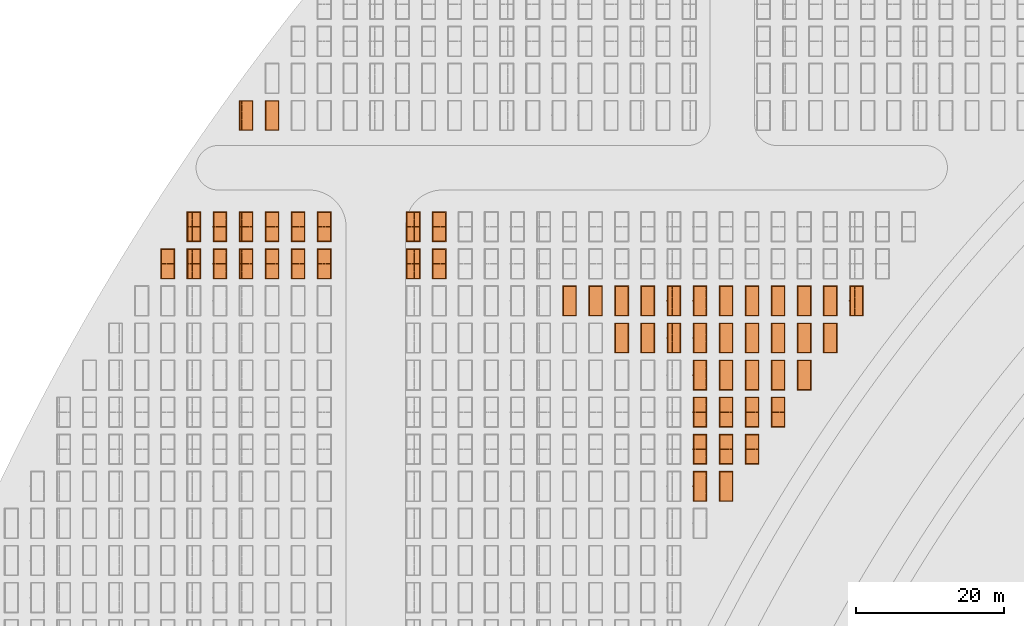
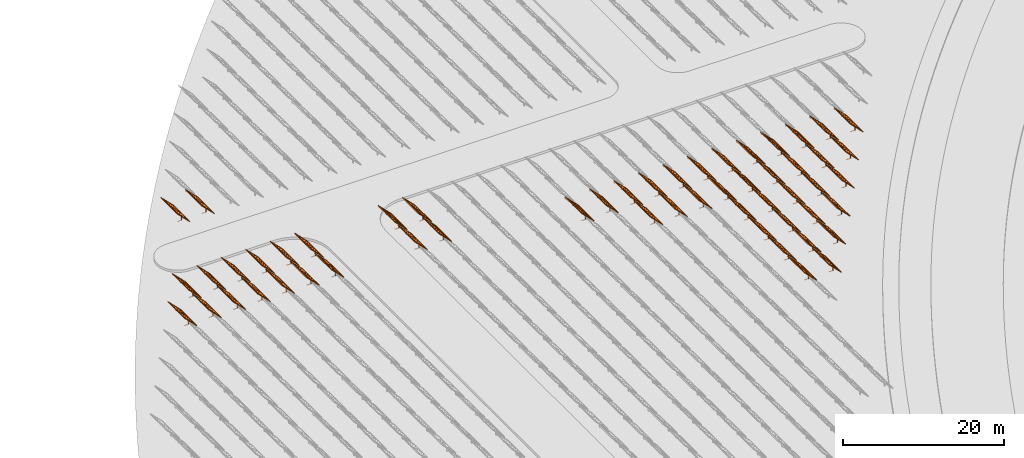
# One storey, part 32 of 39: 54 proxies.
"""IFC2X3 building model written with IfcOpenShell, lengths in millimetres."""

from ifc_helpers import new_model, entity, si_unit, converted_unit, derived_unit, direction, frame, frame_2d, origin, origin_2d_with_axis, place, context, subcontext, project, spatial, polyline, rectangle, outline, extrude, source, transform, mapped, material, material_list, element, save


model = new_model("IFC2X3")

# Units and contexts
model_context = context("Model", 3, precision=1e-06, world=origin(), true_north=direction((2.0, 6.12303176911189e-17, 1.0)))
context_of_model = context(None, 3, precision=1e-06, world=origin(), true_north=direction((2.0, 6.12303176911189e-17, 1.0)))
body_context = subcontext(model_context, "Body", "Model", "MODEL_VIEW")
ifc_project = project(units=[si_unit("LENGTHUNIT", "METRE", prefix="MILLI"), si_unit("AREAUNIT", "SQUARE_METRE", prefix="MILLI"), si_unit("VOLUMEUNIT", "CUBIC_METRE", prefix="MILLI"), converted_unit("PLANEANGLEUNIT", "DEGREE", entity("IfcRatioMeasure", 0.0174532925199433), si_unit("PLANEANGLEUNIT", "RADIAN"), dimensions=[0, 0, 0, 0, 0, 0, 0]), si_unit("MASSUNIT", "GRAM", prefix="KILO"), si_unit("TIMEUNIT", "SECOND"), si_unit("THERMODYNAMICTEMPERATUREUNIT", "KELVIN"), derived_unit("THERMALTRANSMITTANCEUNIT", [(si_unit("MASSUNIT", "GRAM", prefix="KILO"), 1), (si_unit("THERMODYNAMICTEMPERATUREUNIT", "KELVIN"), -1), (si_unit("TIMEUNIT", "SECOND"), -3)]), derived_unit("VOLUMETRICFLOWRATEUNIT", [(si_unit("LENGTHUNIT", "METRE"), 3), (si_unit("TIMEUNIT", "SECOND"), -1)])], contexts=[model_context, context_of_model])

# Site, building, storey
site_placement = place(None, origin())
site = spatial("IfcSite", under=ifc_project, at=site_placement, CompositionType="ELEMENT")
building_placement = place(site_placement, origin())
building = spatial("IfcBuilding", under=site, at=building_placement, CompositionType="ELEMENT")
storey_placement = place(building_placement, frame((0.0, 0.0, 4000.0)))
storey = spatial("IfcBuildingStorey", under=building, at=storey_placement, Name="Level 2", CompositionType="ELEMENT", Elevation=4000.0)

# Proxies
ifc_material_1 = material(Name="Stand-Steel")
ifc_material_2 = material(Name="Aluminium")
ifc_material_3 = material(Name="Glass")
ifc_material_list_1 = material_list([ifc_material_1, ifc_material_2, ifc_material_3])
shared_shape = source(origin(), body_context, "Body", "SweptSolid", [
    extrude(outline(polyline([(-629.526235435404, -220.0), (329.763117717702, -220.0), (329.763117717703, 410.0), (299.763117717703, 410.0), (299.763117717702, -190.0), (-629.526235435404, -190.0), (-629.526235435404, -220.0)])), frame((-190.00003127179, -100.0, 299.763117717707), z_axis=(0.0, 1.0, 0.0), x_axis=(0.0, 0.0, -1.0)), (0.0, 0.0, 1.0), 200.0),
    extrude(rectangle(XDim=20.0000000000001, YDim=200.0, at=frame_2d((0.0, -7.105427357601e-14), x_axis=(0.0, 1.0))), frame((-7.07109908365613, 0.0, 922.21828534124), z_axis=(-0.70710678118654, 0.0, 0.707106781186555), x_axis=(0.0, 1.0, 0.0)), (0.0, 0.0, 1.0), 2600.0),
    extrude(rectangle(XDim=24.9999999999997, YDim=24.9999999999999, at=frame_2d((2.87769807982841e-13, -9.50350909079134e-14), x_axis=(1.0, 0.0))), frame((-1449.56292018118, -1950.0, 2449.57494522722), z_axis=(0.0, 1.0, 0.0), x_axis=(-0.707106781186548, 0.0, -0.707106781186548)), (0.0, 0.0, 1.0), 3900.0),
    extrude(rectangle(XDim=24.9999999999999, YDim=25.0000000000001, at=origin_2d_with_axis()), frame((-1096.0095295879, -1950.0, 2096.02155463395), z_axis=(0.0, 1.0, 0.0), x_axis=(-0.707106781186542, 0.0, -0.707106781186553)), (0.0, 0.0, 1.0), 3900.0),
    extrude(rectangle(XDim=24.9999999999999, YDim=25.0000000000001, at=origin_2d_with_axis()), frame((-742.456138994631, -1950.0, 1742.46816404067), z_axis=(0.0, 1.0, 0.0), x_axis=(-0.707106781186542, 0.0, -0.707106781186553)), (0.0, 0.0, 1.0), 3900.0),
    extrude(rectangle(XDim=25.0, YDim=24.9999999999997, at=frame_2d((-7.19424519957101e-14, 1.19904086659517e-13), x_axis=(1.0, 0.0))), frame((-388.902748401358, -1950.0, 1388.9147734474), z_axis=(0.0, 1.0, 0.0), x_axis=(-0.707106781186545, 0.0, -0.70710678118655)), (0.0, 0.0, 1.0), 3900.0),
    extrude(rectangle(XDim=25.0000000000002, YDim=25.0, at=frame_2d((1.35891298214119e-13, 6.21724893790088e-15), x_axis=(0.0, 1.0))), frame((-35.3553703311048, 1500.0, 1035.35537033109), z_axis=(-0.707106781186544, 0.0, 0.707106781186551), x_axis=(0.0, 1.0, 0.0)), (0.0, 0.0, 1.0), 2440.0),
    extrude(rectangle(XDim=25.0000000000002, YDim=25.0, at=frame_2d((0.0, 1.77635683940025e-15), x_axis=(0.0, 1.0))), frame((-35.3553703311059, 1000.0, 1035.35537033109), z_axis=(-0.707106781186546, 0.0, 0.707106781186549), x_axis=(0.0, 1.0, 0.0)), (0.0, 0.0, 1.0), 2440.0),
    extrude(rectangle(XDim=25.0000000000002, YDim=25.0, at=frame_2d((0.0, 8.43769498715119e-14), x_axis=(0.0, 1.0))), frame((-26.5165355662756, 0.0, 1044.19420509593), z_axis=(-0.707106781186546, 0.0, 0.707106781186549), x_axis=(0.0, -1.0, 0.0)), (0.0, 0.0, 1.0), 2440.0),
    extrude(rectangle(XDim=25.0000000000002, YDim=25.0, at=frame_2d((0.0, 8.88178419700125e-16), x_axis=(0.0, 1.0))), frame((-35.3553703311065, 500.0, 1035.35537033109), z_axis=(-0.707106781186546, 0.0, 0.707106781186549), x_axis=(0.0, 1.0, 0.0)), (0.0, 0.0, 1.0), 2440.0),
    extrude(rectangle(XDim=25.0000000000002, YDim=25.0, at=frame_2d((0.0, 8.88178419700125e-16), x_axis=(0.0, 1.0))), frame((-35.3553703311086, -500.0, 1035.35537033109), z_axis=(-0.707106781186546, 0.0, 0.707106781186549), x_axis=(0.0, 1.0, 0.0)), (0.0, 0.0, 1.0), 2440.0),
    extrude(rectangle(XDim=25.0000000000002, YDim=25.0, at=frame_2d((0.0, 8.88178419700125e-16), x_axis=(0.0, 1.0))), frame((-35.3553703311095, -1000.0, 1035.35537033109), z_axis=(-0.707106781186546, 0.0, 0.707106781186549), x_axis=(0.0, 1.0, 0.0)), (0.0, 0.0, 1.0), 2440.0),
    extrude(rectangle(XDim=25.0000000000002, YDim=25.0, at=frame_2d((1.35891298214119e-13, 1.77635683940025e-15), x_axis=(0.0, 1.0))), frame((-35.3553703311107, -1500.0, 1035.35537033109), z_axis=(-0.707106781186546, 0.0, 0.707106781186549), x_axis=(0.0, 1.0, 0.0)), (0.0, 0.0, 1.0), 2440.0),
    extrude(rectangle(XDim=2400.0, YDim=11.9999999999994, at=frame_2d((-1.13686837721616e-13, 2.02948768901479e-13), x_axis=(1.0, 0.0))), frame((-883.883507754966, -1950.0, 1883.88350775495), z_axis=(0.0, 1.0, 0.0), x_axis=(0.707106781186546, 0.0, -0.707106781186549)), (0.0, 0.0, 1.0), 3900.0),
    extrude(outline(polyline([(-2050.0, -1300.0), (2050.0, -1300.0), (2050.0, 1300.0), (-2050.0, 1300.0), (-2050.0, -1300.0)]), holes=[polyline([(1950.0, -1200.0), (-1950.0, -1200.0), (-1950.0, 1200.0), (1950.0, 1200.0), (1950.0, -1200.0)])]), frame((-919.238846814293, 0.0, 1848.52816869563), z_axis=(0.707106781186554, 0.0, 0.707106781186541), x_axis=(0.0, 1.0, 0.0)), (0.0, 0.0, 1.0), 99.9999999999898),
])
proxy_1_placement = place(storey_placement, frame((-126810.276453181, 620144.680552408, 30.0)))
element("IfcBuildingElementProxy", 1, at=proxy_1_placement, inside=storey, material=ifc_material_list_1, Name="Solar Panel_4000X2500:Solar Panel_4000X2500", ObjectType="Solar Panel_4000X2500", CompositionType="ELEMENT", context=body_context, shape_type="MappedRepresentation", body=[
    mapped(shared_shape, transform((0.0, 0.0, 0.0), scale=1.0)),
])
ifc_material_list_2 = material_list([ifc_material_1, ifc_material_2, ifc_material_3])
proxy_2_placement = place(storey_placement, frame((-123295.266081452, 620144.680552408, 30.0)))
element("IfcBuildingElementProxy", 2, at=proxy_2_placement, inside=storey, material=ifc_material_list_2, Name="Solar Panel_4000X2500:Solar Panel_4000X2500", ObjectType="Solar Panel_4000X2500", CompositionType="ELEMENT", context=body_context, shape_type="MappedRepresentation", body=[
    mapped(shared_shape, transform((0.0, 0.0, 0.0), scale=1.0)),
])
ifc_material_list_3 = material_list([ifc_material_1, ifc_material_2, ifc_material_3])
proxy_3_placement = place(storey_placement, frame((-119780.255709722, 615144.680552408, 30.0)))
element("IfcBuildingElementProxy", 3, at=proxy_3_placement, inside=storey, material=ifc_material_list_3, Name="Solar Panel_4000X2500:Solar Panel_4000X2500", ObjectType="Solar Panel_4000X2500", CompositionType="ELEMENT", context=body_context, shape_type="MappedRepresentation", body=[
    mapped(shared_shape, transform((0.0, 0.0, 0.0), scale=1.0)),
])
ifc_material_list_4 = material_list([ifc_material_1, ifc_material_2, ifc_material_3])
proxy_4_placement = place(storey_placement, frame((-119780.255709722, 620144.680552408, 30.0)))
element("IfcBuildingElementProxy", 4, at=proxy_4_placement, inside=storey, material=ifc_material_list_4, Name="Solar Panel_4000X2500:Solar Panel_4000X2500", ObjectType="Solar Panel_4000X2500", CompositionType="ELEMENT", context=body_context, shape_type="MappedRepresentation", body=[
    mapped(shared_shape, transform((0.0, 0.0, 0.0), scale=1.0)),
])
ifc_material_list_5 = material_list([ifc_material_1, ifc_material_2, ifc_material_3])
proxy_5_placement = place(storey_placement, frame((-116265.245337992, 615144.680552408, 30.0)))
element("IfcBuildingElementProxy", 5, at=proxy_5_placement, inside=storey, material=ifc_material_list_5, Name="Solar Panel_4000X2500:Solar Panel_4000X2500", ObjectType="Solar Panel_4000X2500", CompositionType="ELEMENT", context=body_context, shape_type="MappedRepresentation", body=[
    mapped(shared_shape, transform((0.0, 0.0, 0.0), scale=1.0)),
])
ifc_material_list_6 = material_list([ifc_material_1, ifc_material_2, ifc_material_3])
proxy_6_placement = place(storey_placement, frame((-116265.245337992, 620144.680552408, 30.0)))
element("IfcBuildingElementProxy", 6, at=proxy_6_placement, inside=storey, material=ifc_material_list_6, Name="Solar Panel_4000X2500:Solar Panel_4000X2500", ObjectType="Solar Panel_4000X2500", CompositionType="ELEMENT", context=body_context, shape_type="MappedRepresentation", body=[
    mapped(shared_shape, transform((0.0, 0.0, 0.0), scale=1.0)),
])
ifc_material_list_7 = material_list([ifc_material_1, ifc_material_2, ifc_material_3])
proxy_7_placement = place(storey_placement, frame((-112750.234966262, 615144.680552408, 30.0)))
element("IfcBuildingElementProxy", 7, at=proxy_7_placement, inside=storey, material=ifc_material_list_7, Name="Solar Panel_4000X2500:Solar Panel_4000X2500", ObjectType="Solar Panel_4000X2500", CompositionType="ELEMENT", context=body_context, shape_type="MappedRepresentation", body=[
    mapped(shared_shape, transform((0.0, 0.0, 0.0), scale=1.0)),
])
ifc_material_list_8 = material_list([ifc_material_1, ifc_material_2, ifc_material_3])
proxy_8_placement = place(storey_placement, frame((-112750.234966262, 620144.680552408, 30.0)))
element("IfcBuildingElementProxy", 8, at=proxy_8_placement, inside=storey, material=ifc_material_list_8, Name="Solar Panel_4000X2500:Solar Panel_4000X2500", ObjectType="Solar Panel_4000X2500", CompositionType="ELEMENT", context=body_context, shape_type="MappedRepresentation", body=[
    mapped(shared_shape, transform((0.0, 0.0, 0.0), scale=1.0)),
])
ifc_material_list_9 = material_list([ifc_material_1, ifc_material_2, ifc_material_3])
proxy_9_placement = place(storey_placement, frame((-109235.224594532, 595144.680552408, 30.0)))
element("IfcBuildingElementProxy", 9, at=proxy_9_placement, inside=storey, material=ifc_material_list_9, Name="Solar Panel_4000X2500:Solar Panel_4000X2500", ObjectType="Solar Panel_4000X2500", CompositionType="ELEMENT", context=body_context, shape_type="MappedRepresentation", body=[
    mapped(shared_shape, transform((0.0, 0.0, 0.0), scale=1.0)),
])
ifc_material_list_10 = material_list([ifc_material_1, ifc_material_2, ifc_material_3])
proxy_10_placement = place(storey_placement, frame((-109235.224594532, 600144.680552408, 30.0)))
element("IfcBuildingElementProxy", 10, at=proxy_10_placement, inside=storey, material=ifc_material_list_10, Name="Solar Panel_4000X2500:Solar Panel_4000X2500", ObjectType="Solar Panel_4000X2500", CompositionType="ELEMENT", context=body_context, shape_type="MappedRepresentation", body=[
    mapped(shared_shape, transform((0.0, 0.0, 0.0), scale=1.0)),
])
ifc_material_list_11 = material_list([ifc_material_1, ifc_material_2, ifc_material_3])
proxy_11_placement = place(storey_placement, frame((-109235.224594532, 605144.680552408, 30.0)))
element("IfcBuildingElementProxy", 11, at=proxy_11_placement, inside=storey, material=ifc_material_list_11, Name="Solar Panel_4000X2500:Solar Panel_4000X2500", ObjectType="Solar Panel_4000X2500", CompositionType="ELEMENT", context=body_context, shape_type="MappedRepresentation", body=[
    mapped(shared_shape, transform((0.0, 0.0, 0.0), scale=1.0)),
])
ifc_material_list_12 = material_list([ifc_material_1, ifc_material_2, ifc_material_3])
proxy_12_placement = place(storey_placement, frame((-109235.224594532, 610144.680552408, 30.0)))
element("IfcBuildingElementProxy", 12, at=proxy_12_placement, inside=storey, material=ifc_material_list_12, Name="Solar Panel_4000X2500:Solar Panel_4000X2500", ObjectType="Solar Panel_4000X2500", CompositionType="ELEMENT", context=body_context, shape_type="MappedRepresentation", body=[
    mapped(shared_shape, transform((0.0, 0.0, 0.0), scale=1.0)),
])
ifc_material_list_13 = material_list([ifc_material_1, ifc_material_2, ifc_material_3])
proxy_13_placement = place(storey_placement, frame((-109235.224594532, 615144.680552408, 30.0)))
element("IfcBuildingElementProxy", 13, at=proxy_13_placement, inside=storey, material=ifc_material_list_13, Name="Solar Panel_4000X2500:Solar Panel_4000X2500", ObjectType="Solar Panel_4000X2500", CompositionType="ELEMENT", context=body_context, shape_type="MappedRepresentation", body=[
    mapped(shared_shape, transform((0.0, 0.0, 0.0), scale=1.0)),
])
ifc_material_list_14 = material_list([ifc_material_1, ifc_material_2, ifc_material_3])
proxy_14_placement = place(storey_placement, frame((-109235.224594532, 620144.680552408, 30.0)))
element("IfcBuildingElementProxy", 14, at=proxy_14_placement, inside=storey, material=ifc_material_list_14, Name="Solar Panel_4000X2500:Solar Panel_4000X2500", ObjectType="Solar Panel_4000X2500", CompositionType="ELEMENT", context=body_context, shape_type="MappedRepresentation", body=[
    mapped(shared_shape, transform((0.0, 0.0, 0.0), scale=1.0)),
])
ifc_material_list_15 = material_list([ifc_material_1, ifc_material_2, ifc_material_3])
proxy_15_placement = place(storey_placement, frame((-105720.214222803, 595144.680552408, 30.0)))
element("IfcBuildingElementProxy", 15, at=proxy_15_placement, inside=storey, material=ifc_material_list_15, Name="Solar Panel_4000X2500:Solar Panel_4000X2500", ObjectType="Solar Panel_4000X2500", CompositionType="ELEMENT", context=body_context, shape_type="MappedRepresentation", body=[
    mapped(shared_shape, transform((0.0, 0.0, 0.0), scale=1.0)),
])
ifc_material_list_16 = material_list([ifc_material_1, ifc_material_2, ifc_material_3])
proxy_16_placement = place(storey_placement, frame((-105720.214222803, 600144.680552408, 30.0)))
element("IfcBuildingElementProxy", 16, at=proxy_16_placement, inside=storey, material=ifc_material_list_16, Name="Solar Panel_4000X2500:Solar Panel_4000X2500", ObjectType="Solar Panel_4000X2500", CompositionType="ELEMENT", context=body_context, shape_type="MappedRepresentation", body=[
    mapped(shared_shape, transform((0.0, 0.0, 0.0), scale=1.0)),
])
ifc_material_list_17 = material_list([ifc_material_1, ifc_material_2, ifc_material_3])
proxy_17_placement = place(storey_placement, frame((-105720.214222803, 605144.680552408, 30.0)))
element("IfcBuildingElementProxy", 17, at=proxy_17_placement, inside=storey, material=ifc_material_list_17, Name="Solar Panel_4000X2500:Solar Panel_4000X2500", ObjectType="Solar Panel_4000X2500", CompositionType="ELEMENT", context=body_context, shape_type="MappedRepresentation", body=[
    mapped(shared_shape, transform((0.0, 0.0, 0.0), scale=1.0)),
])
ifc_material_list_18 = material_list([ifc_material_1, ifc_material_2, ifc_material_3])
proxy_18_placement = place(storey_placement, frame((-105720.214222803, 610144.680552408, 30.0)))
element("IfcBuildingElementProxy", 18, at=proxy_18_placement, inside=storey, material=ifc_material_list_18, Name="Solar Panel_4000X2500:Solar Panel_4000X2500", ObjectType="Solar Panel_4000X2500", CompositionType="ELEMENT", context=body_context, shape_type="MappedRepresentation", body=[
    mapped(shared_shape, transform((0.0, 0.0, 0.0), scale=1.0)),
])
ifc_material_list_19 = material_list([ifc_material_1, ifc_material_2, ifc_material_3])
proxy_19_placement = place(storey_placement, frame((-105720.214222803, 615144.680552408, 30.0)))
element("IfcBuildingElementProxy", 19, at=proxy_19_placement, inside=storey, material=ifc_material_list_19, Name="Solar Panel_4000X2500:Solar Panel_4000X2500", ObjectType="Solar Panel_4000X2500", CompositionType="ELEMENT", context=body_context, shape_type="MappedRepresentation", body=[
    mapped(shared_shape, transform((0.0, 0.0, 0.0), scale=1.0)),
])
ifc_material_list_20 = material_list([ifc_material_1, ifc_material_2, ifc_material_3])
proxy_20_placement = place(storey_placement, frame((-105720.214222803, 620144.680552408, 30.0)))
element("IfcBuildingElementProxy", 20, at=proxy_20_placement, inside=storey, material=ifc_material_list_20, Name="Solar Panel_4000X2500:Solar Panel_4000X2500", ObjectType="Solar Panel_4000X2500", CompositionType="ELEMENT", context=body_context, shape_type="MappedRepresentation", body=[
    mapped(shared_shape, transform((0.0, 0.0, 0.0), scale=1.0)),
])
ifc_material_list_21 = material_list([ifc_material_1, ifc_material_2, ifc_material_3])
proxy_21_placement = place(storey_placement, frame((-102205.203851073, 600144.680552408, 30.0)))
element("IfcBuildingElementProxy", 21, at=proxy_21_placement, inside=storey, material=ifc_material_list_21, Name="Solar Panel_4000X2500:Solar Panel_4000X2500", ObjectType="Solar Panel_4000X2500", CompositionType="ELEMENT", context=body_context, shape_type="MappedRepresentation", body=[
    mapped(shared_shape, transform((0.0, 0.0, 0.0), scale=1.0)),
])
ifc_material_list_22 = material_list([ifc_material_1, ifc_material_2, ifc_material_3])
proxy_22_placement = place(storey_placement, frame((-102205.203851073, 605144.680552408, 30.0)))
element("IfcBuildingElementProxy", 22, at=proxy_22_placement, inside=storey, material=ifc_material_list_22, Name="Solar Panel_4000X2500:Solar Panel_4000X2500", ObjectType="Solar Panel_4000X2500", CompositionType="ELEMENT", context=body_context, shape_type="MappedRepresentation", body=[
    mapped(shared_shape, transform((0.0, 0.0, 0.0), scale=1.0)),
])
ifc_material_list_23 = material_list([ifc_material_1, ifc_material_2, ifc_material_3])
proxy_23_placement = place(storey_placement, frame((-102205.203851073, 610144.680552408, 30.0)))
element("IfcBuildingElementProxy", 23, at=proxy_23_placement, inside=storey, material=ifc_material_list_23, Name="Solar Panel_4000X2500:Solar Panel_4000X2500", ObjectType="Solar Panel_4000X2500", CompositionType="ELEMENT", context=body_context, shape_type="MappedRepresentation", body=[
    mapped(shared_shape, transform((0.0, 0.0, 0.0), scale=1.0)),
])
ifc_material_list_24 = material_list([ifc_material_1, ifc_material_2, ifc_material_3])
proxy_24_placement = place(storey_placement, frame((-102205.203851073, 615144.680552408, 30.0)))
element("IfcBuildingElementProxy", 24, at=proxy_24_placement, inside=storey, material=ifc_material_list_24, Name="Solar Panel_4000X2500:Solar Panel_4000X2500", ObjectType="Solar Panel_4000X2500", CompositionType="ELEMENT", context=body_context, shape_type="MappedRepresentation", body=[
    mapped(shared_shape, transform((0.0, 0.0, 0.0), scale=1.0)),
])
ifc_material_list_25 = material_list([ifc_material_1, ifc_material_2, ifc_material_3])
proxy_25_placement = place(storey_placement, frame((-102205.203851073, 620144.680552408, 30.0)))
element("IfcBuildingElementProxy", 25, at=proxy_25_placement, inside=storey, material=ifc_material_list_25, Name="Solar Panel_4000X2500:Solar Panel_4000X2500", ObjectType="Solar Panel_4000X2500", CompositionType="ELEMENT", context=body_context, shape_type="MappedRepresentation", body=[
    mapped(shared_shape, transform((0.0, 0.0, 0.0), scale=1.0)),
])
ifc_material_list_26 = material_list([ifc_material_1, ifc_material_2, ifc_material_3])
proxy_26_placement = place(storey_placement, frame((-98690.193479343, 605144.680552408, 30.0)))
element("IfcBuildingElementProxy", 26, at=proxy_26_placement, inside=storey, material=ifc_material_list_26, Name="Solar Panel_4000X2500:Solar Panel_4000X2500", ObjectType="Solar Panel_4000X2500", CompositionType="ELEMENT", context=body_context, shape_type="MappedRepresentation", body=[
    mapped(shared_shape, transform((0.0, 0.0, 0.0), scale=1.0)),
])
ifc_material_list_27 = material_list([ifc_material_1, ifc_material_2, ifc_material_3])
proxy_27_placement = place(storey_placement, frame((-98690.193479343, 610144.680552408, 30.0)))
element("IfcBuildingElementProxy", 27, at=proxy_27_placement, inside=storey, material=ifc_material_list_27, Name="Solar Panel_4000X2500:Solar Panel_4000X2500", ObjectType="Solar Panel_4000X2500", CompositionType="ELEMENT", context=body_context, shape_type="MappedRepresentation", body=[
    mapped(shared_shape, transform((0.0, 0.0, 0.0), scale=1.0)),
])
ifc_material_list_28 = material_list([ifc_material_1, ifc_material_2, ifc_material_3])
proxy_28_placement = place(storey_placement, frame((-98690.193479343, 615144.680552408, 30.0)))
element("IfcBuildingElementProxy", 28, at=proxy_28_placement, inside=storey, material=ifc_material_list_28, Name="Solar Panel_4000X2500:Solar Panel_4000X2500", ObjectType="Solar Panel_4000X2500", CompositionType="ELEMENT", context=body_context, shape_type="MappedRepresentation", body=[
    mapped(shared_shape, transform((0.0, 0.0, 0.0), scale=1.0)),
])
ifc_material_list_29 = material_list([ifc_material_1, ifc_material_2, ifc_material_3])
proxy_29_placement = place(storey_placement, frame((-98690.193479343, 620144.680552408, 30.0)))
element("IfcBuildingElementProxy", 29, at=proxy_29_placement, inside=storey, material=ifc_material_list_29, Name="Solar Panel_4000X2500:Solar Panel_4000X2500", ObjectType="Solar Panel_4000X2500", CompositionType="ELEMENT", context=body_context, shape_type="MappedRepresentation", body=[
    mapped(shared_shape, transform((0.0, 0.0, 0.0), scale=1.0)),
])
ifc_material_list_30 = material_list([ifc_material_1, ifc_material_2, ifc_material_3])
proxy_30_placement = place(storey_placement, frame((-95175.1831076132, 610144.680552408, 30.0)))
element("IfcBuildingElementProxy", 30, at=proxy_30_placement, inside=storey, material=ifc_material_list_30, Name="Solar Panel_4000X2500:Solar Panel_4000X2500", ObjectType="Solar Panel_4000X2500", CompositionType="ELEMENT", context=body_context, shape_type="MappedRepresentation", body=[
    mapped(shared_shape, transform((0.0, 0.0, 0.0), scale=1.0)),
])
ifc_material_list_31 = material_list([ifc_material_1, ifc_material_2, ifc_material_3])
proxy_31_placement = place(storey_placement, frame((-95175.1831076132, 615144.680552408, 30.0)))
element("IfcBuildingElementProxy", 31, at=proxy_31_placement, inside=storey, material=ifc_material_list_31, Name="Solar Panel_4000X2500:Solar Panel_4000X2500", ObjectType="Solar Panel_4000X2500", CompositionType="ELEMENT", context=body_context, shape_type="MappedRepresentation", body=[
    mapped(shared_shape, transform((0.0, 0.0, 0.0), scale=1.0)),
])
ifc_material_list_32 = material_list([ifc_material_1, ifc_material_2, ifc_material_3])
proxy_32_placement = place(storey_placement, frame((-95175.1831076132, 620144.680552408, 30.0)))
element("IfcBuildingElementProxy", 32, at=proxy_32_placement, inside=storey, material=ifc_material_list_32, Name="Solar Panel_4000X2500:Solar Panel_4000X2500", ObjectType="Solar Panel_4000X2500", CompositionType="ELEMENT", context=body_context, shape_type="MappedRepresentation", body=[
    mapped(shared_shape, transform((0.0, 0.0, 0.0), scale=1.0)),
])
ifc_material_list_33 = material_list([ifc_material_1, ifc_material_2, ifc_material_3])
proxy_33_placement = place(storey_placement, frame((-91660.1727358834, 615144.680552408, 30.0)))
element("IfcBuildingElementProxy", 33, at=proxy_33_placement, inside=storey, material=ifc_material_list_33, Name="Solar Panel_4000X2500:Solar Panel_4000X2500", ObjectType="Solar Panel_4000X2500", CompositionType="ELEMENT", context=body_context, shape_type="MappedRepresentation", body=[
    mapped(shared_shape, transform((0.0, 0.0, 0.0), scale=1.0)),
])
ifc_material_list_34 = material_list([ifc_material_1, ifc_material_2, ifc_material_3])
proxy_34_placement = place(storey_placement, frame((-91660.1727358834, 620144.680552408, 30.0)))
element("IfcBuildingElementProxy", 34, at=proxy_34_placement, inside=storey, material=ifc_material_list_34, Name="Solar Panel_4000X2500:Solar Panel_4000X2500", ObjectType="Solar Panel_4000X2500", CompositionType="ELEMENT", context=body_context, shape_type="MappedRepresentation", body=[
    mapped(shared_shape, transform((0.0, 0.0, 0.0), scale=1.0)),
])
ifc_material_list_35 = material_list([ifc_material_1, ifc_material_2, ifc_material_3])
proxy_35_placement = place(storey_placement, frame((-88145.1623641536, 620144.680552408, 30.0)))
element("IfcBuildingElementProxy", 35, at=proxy_35_placement, inside=storey, material=ifc_material_list_35, Name="Solar Panel_4000X2500:Solar Panel_4000X2500", ObjectType="Solar Panel_4000X2500", CompositionType="ELEMENT", context=body_context, shape_type="MappedRepresentation", body=[
    mapped(shared_shape, transform((0.0, 0.0, 0.0), scale=1.0)),
])
ifc_material_list_36 = material_list([ifc_material_1, ifc_material_2, ifc_material_3])
proxy_36_placement = place(storey_placement, frame((-144385.32831183, 625144.680552408, 30.0)))
element("IfcBuildingElementProxy", 36, at=proxy_36_placement, inside=storey, material=ifc_material_list_36, Name="Solar Panel_4000X2500:Solar Panel_4000X2500", ObjectType="Solar Panel_4000X2500", CompositionType="ELEMENT", context=body_context, shape_type="MappedRepresentation", body=[
    mapped(shared_shape, transform((0.0, 0.0, 0.0), scale=1.0)),
])
ifc_material_list_37 = material_list([ifc_material_1, ifc_material_2, ifc_material_3])
proxy_37_placement = place(storey_placement, frame((-144385.32831183, 630144.680552408, 30.0)))
element("IfcBuildingElementProxy", 37, at=proxy_37_placement, inside=storey, material=ifc_material_list_37, Name="Solar Panel_4000X2500:Solar Panel_4000X2500", ObjectType="Solar Panel_4000X2500", CompositionType="ELEMENT", context=body_context, shape_type="MappedRepresentation", body=[
    mapped(shared_shape, transform((0.0, 0.0, 0.0), scale=1.0)),
])
ifc_material_list_38 = material_list([ifc_material_1, ifc_material_2, ifc_material_3])
proxy_38_placement = place(storey_placement, frame((-147885.32831183, 625144.680552408, 30.0)))
element("IfcBuildingElementProxy", 38, at=proxy_38_placement, inside=storey, material=ifc_material_list_38, Name="Solar Panel_4000X2500:Solar Panel_4000X2500", ObjectType="Solar Panel_4000X2500", CompositionType="ELEMENT", context=body_context, shape_type="MappedRepresentation", body=[
    mapped(shared_shape, transform((0.0, 0.0, 0.0), scale=1.0)),
])
ifc_material_list_39 = material_list([ifc_material_1, ifc_material_2, ifc_material_3])
proxy_39_placement = place(storey_placement, frame((-147885.32831183, 630144.680552408, 30.0)))
element("IfcBuildingElementProxy", 39, at=proxy_39_placement, inside=storey, material=ifc_material_list_39, Name="Solar Panel_4000X2500:Solar Panel_4000X2500", ObjectType="Solar Panel_4000X2500", CompositionType="ELEMENT", context=body_context, shape_type="MappedRepresentation", body=[
    mapped(shared_shape, transform((0.0, 0.0, 0.0), scale=1.0)),
])
ifc_material_list_40 = material_list([ifc_material_1, ifc_material_2, ifc_material_3])
proxy_40_placement = place(storey_placement, frame((-159885.32831183, 625144.680552408, 30.0)))
element("IfcBuildingElementProxy", 40, at=proxy_40_placement, inside=storey, material=ifc_material_list_40, Name="Solar Panel_4000X2500:Solar Panel_4000X2500", ObjectType="Solar Panel_4000X2500", CompositionType="ELEMENT", context=body_context, shape_type="MappedRepresentation", body=[
    mapped(shared_shape, transform((0.0, 0.0, 0.0), scale=1.0)),
])
ifc_material_list_41 = material_list([ifc_material_1, ifc_material_2, ifc_material_3])
proxy_41_placement = place(storey_placement, frame((-159885.32831183, 630144.680552408, 30.0)))
element("IfcBuildingElementProxy", 41, at=proxy_41_placement, inside=storey, material=ifc_material_list_41, Name="Solar Panel_4000X2500:Solar Panel_4000X2500", ObjectType="Solar Panel_4000X2500", CompositionType="ELEMENT", context=body_context, shape_type="MappedRepresentation", body=[
    mapped(shared_shape, transform((0.0, 0.0, 0.0), scale=1.0)),
])
ifc_material_list_42 = material_list([ifc_material_1, ifc_material_2, ifc_material_3])
proxy_42_placement = place(storey_placement, frame((-163400.32831183, 625144.680552408, 30.0)))
element("IfcBuildingElementProxy", 42, at=proxy_42_placement, inside=storey, material=ifc_material_list_42, Name="Solar Panel_4000X2500:Solar Panel_4000X2500", ObjectType="Solar Panel_4000X2500", CompositionType="ELEMENT", context=body_context, shape_type="MappedRepresentation", body=[
    mapped(shared_shape, transform((0.0, 0.0, 0.0), scale=1.0)),
])
ifc_material_list_43 = material_list([ifc_material_1, ifc_material_2, ifc_material_3])
proxy_43_placement = place(storey_placement, frame((-163400.32831183, 630144.680552408, 30.0)))
element("IfcBuildingElementProxy", 43, at=proxy_43_placement, inside=storey, material=ifc_material_list_43, Name="Solar Panel_4000X2500:Solar Panel_4000X2500", ObjectType="Solar Panel_4000X2500", CompositionType="ELEMENT", context=body_context, shape_type="MappedRepresentation", body=[
    mapped(shared_shape, transform((0.0, 0.0, 0.0), scale=1.0)),
])
ifc_material_list_44 = material_list([ifc_material_1, ifc_material_2, ifc_material_3])
proxy_44_placement = place(storey_placement, frame((-166915.32831183, 625144.680552408, 30.0)))
element("IfcBuildingElementProxy", 44, at=proxy_44_placement, inside=storey, material=ifc_material_list_44, Name="Solar Panel_4000X2500:Solar Panel_4000X2500", ObjectType="Solar Panel_4000X2500", CompositionType="ELEMENT", context=body_context, shape_type="MappedRepresentation", body=[
    mapped(shared_shape, transform((0.0, 0.0, 0.0), scale=1.0)),
])
ifc_material_list_45 = material_list([ifc_material_1, ifc_material_2, ifc_material_3])
proxy_45_placement = place(storey_placement, frame((-166915.32831183, 630144.680552408, 30.0)))
element("IfcBuildingElementProxy", 45, at=proxy_45_placement, inside=storey, material=ifc_material_list_45, Name="Solar Panel_4000X2500:Solar Panel_4000X2500", ObjectType="Solar Panel_4000X2500", CompositionType="ELEMENT", context=body_context, shape_type="MappedRepresentation", body=[
    mapped(shared_shape, transform((0.0, 0.0, 0.0), scale=1.0)),
])
ifc_material_list_46 = material_list([ifc_material_1, ifc_material_2, ifc_material_3])
proxy_46_placement = place(storey_placement, frame((-170430.32831183, 625144.680552408, 30.0)))
element("IfcBuildingElementProxy", 46, at=proxy_46_placement, inside=storey, material=ifc_material_list_46, Name="Solar Panel_4000X2500:Solar Panel_4000X2500", ObjectType="Solar Panel_4000X2500", CompositionType="ELEMENT", context=body_context, shape_type="MappedRepresentation", body=[
    mapped(shared_shape, transform((0.0, 0.0, 0.0), scale=1.0)),
])
ifc_material_list_47 = material_list([ifc_material_1, ifc_material_2, ifc_material_3])
proxy_47_placement = place(storey_placement, frame((-170430.32831183, 630144.680552408, 30.0)))
element("IfcBuildingElementProxy", 47, at=proxy_47_placement, inside=storey, material=ifc_material_list_47, Name="Solar Panel_4000X2500:Solar Panel_4000X2500", ObjectType="Solar Panel_4000X2500", CompositionType="ELEMENT", context=body_context, shape_type="MappedRepresentation", body=[
    mapped(shared_shape, transform((0.0, 0.0, 0.0), scale=1.0)),
])
ifc_material_list_48 = material_list([ifc_material_1, ifc_material_2, ifc_material_3])
proxy_48_placement = place(storey_placement, frame((-173945.32831183, 625144.680552408, 30.0)))
element("IfcBuildingElementProxy", 48, at=proxy_48_placement, inside=storey, material=ifc_material_list_48, Name="Solar Panel_4000X2500:Solar Panel_4000X2500", ObjectType="Solar Panel_4000X2500", CompositionType="ELEMENT", context=body_context, shape_type="MappedRepresentation", body=[
    mapped(shared_shape, transform((0.0, 0.0, 0.0), scale=1.0)),
])
ifc_material_list_49 = material_list([ifc_material_1, ifc_material_2, ifc_material_3])
proxy_49_placement = place(storey_placement, frame((-173945.32831183, 630144.680552408, 30.0)))
element("IfcBuildingElementProxy", 49, at=proxy_49_placement, inside=storey, material=ifc_material_list_49, Name="Solar Panel_4000X2500:Solar Panel_4000X2500", ObjectType="Solar Panel_4000X2500", CompositionType="ELEMENT", context=body_context, shape_type="MappedRepresentation", body=[
    mapped(shared_shape, transform((0.0, 0.0, 0.0), scale=1.0)),
])
ifc_material_list_50 = material_list([ifc_material_1, ifc_material_2, ifc_material_3])
proxy_50_placement = place(storey_placement, frame((-177460.32831183, 625144.680552408, 30.0)))
element("IfcBuildingElementProxy", 50, at=proxy_50_placement, inside=storey, material=ifc_material_list_50, Name="Solar Panel_4000X2500:Solar Panel_4000X2500", ObjectType="Solar Panel_4000X2500", CompositionType="ELEMENT", context=body_context, shape_type="MappedRepresentation", body=[
    mapped(shared_shape, transform((0.0, 0.0, 0.0), scale=1.0)),
])
ifc_material_list_51 = material_list([ifc_material_1, ifc_material_2, ifc_material_3])
proxy_51_placement = place(storey_placement, frame((-177460.32831183, 630144.680552408, 30.0)))
element("IfcBuildingElementProxy", 51, at=proxy_51_placement, inside=storey, material=ifc_material_list_51, Name="Solar Panel_4000X2500:Solar Panel_4000X2500", ObjectType="Solar Panel_4000X2500", CompositionType="ELEMENT", context=body_context, shape_type="MappedRepresentation", body=[
    mapped(shared_shape, transform((0.0, 0.0, 0.0), scale=1.0)),
])
ifc_material_list_52 = material_list([ifc_material_1, ifc_material_2, ifc_material_3])
proxy_52_placement = place(storey_placement, frame((-180975.32831183, 625144.680552408, 30.0)))
element("IfcBuildingElementProxy", 52, at=proxy_52_placement, inside=storey, material=ifc_material_list_52, Name="Solar Panel_4000X2500:Solar Panel_4000X2500", ObjectType="Solar Panel_4000X2500", CompositionType="ELEMENT", context=body_context, shape_type="MappedRepresentation", body=[
    mapped(shared_shape, transform((0.0, 0.0, 0.0), scale=1.0)),
])
ifc_material_list_53 = material_list([ifc_material_1, ifc_material_2, ifc_material_3])
proxy_53_placement = place(storey_placement, frame((-166915.32831183, 645144.680552408, 30.0)))
element("IfcBuildingElementProxy", 53, at=proxy_53_placement, inside=storey, material=ifc_material_list_53, Name="Solar Panel_4000X2500:Solar Panel_4000X2500", ObjectType="Solar Panel_4000X2500", CompositionType="ELEMENT", context=body_context, shape_type="MappedRepresentation", body=[
    mapped(shared_shape, transform((0.0, 0.0, 0.0), scale=1.0)),
])
ifc_material_list_54 = material_list([ifc_material_1, ifc_material_2, ifc_material_3])
proxy_54_placement = place(storey_placement, frame((-170430.32831183, 645144.680552408, 30.0)))
element("IfcBuildingElementProxy", 54, at=proxy_54_placement, inside=storey, material=ifc_material_list_54, Name="Solar Panel_4000X2500:Solar Panel_4000X2500", ObjectType="Solar Panel_4000X2500", CompositionType="ELEMENT", context=body_context, shape_type="MappedRepresentation", body=[
    mapped(shared_shape, transform((0.0, 0.0, 0.0), scale=1.0)),
])

save(model, "model.ifc")
